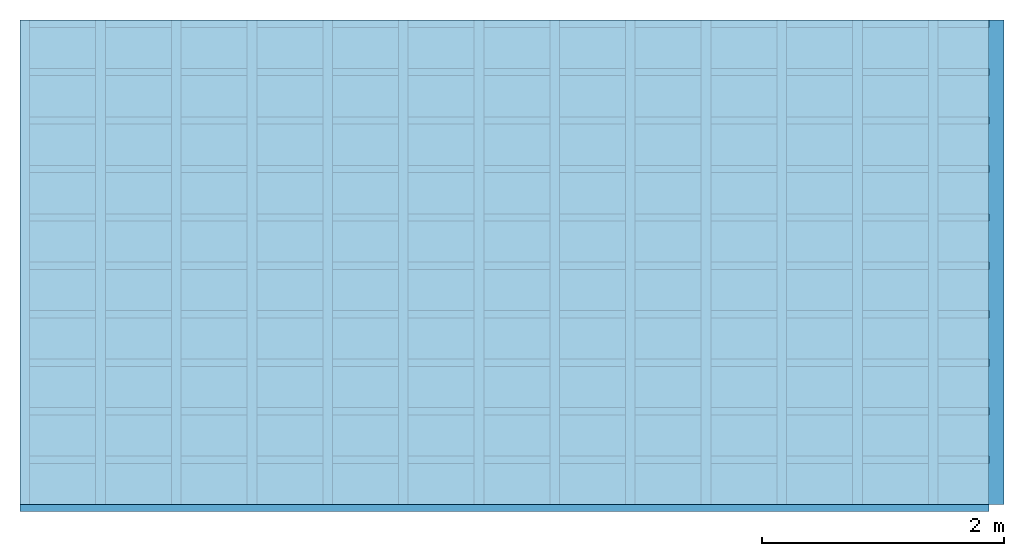
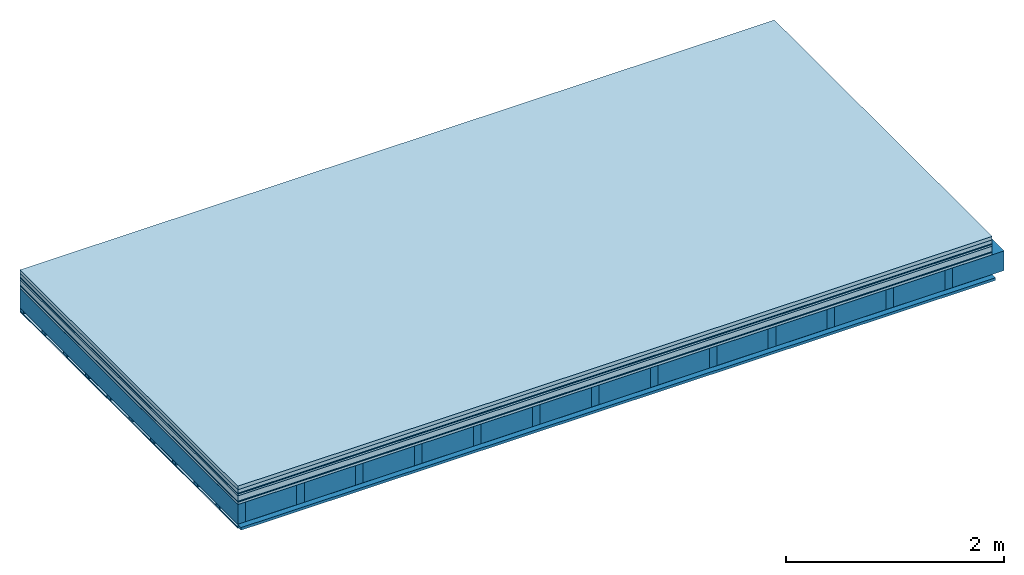
# One storey: 10 plates, 3 members, 1 element without a shape of its own.
"""IFC4 building model written with IfcOpenShell, lengths in metres."""

from ifc_helpers import new_model, si_unit, derived_unit, direction, frame, frame_2d, origin, origin_with_axes, place, context, project, spatial, rectangle, extrude, material, layer, layer_set, type_object, element, aggregate, save


model = new_model("IFC4")

# Units and contexts
plan_context = context("Plan", 3, precision=1e-05, world=origin(), true_north=direction((0.0, 1.0)))
model_context = context("Model", 3, precision=1e-05, world=origin(), true_north=direction((0.0, 1.0)))
ifc_project = project(units=[si_unit("LENGTHUNIT", "METRE"), derived_unit("SOUNDPRESSUREUNIT", [(si_unit("PRESSUREUNIT", "PASCAL", prefix="MICRO"), 0)]), si_unit("ENERGYUNIT", "JOULE", prefix="MEGA"), si_unit("MASSUNIT", "GRAM", prefix="KILO"), derived_unit("THERMALTRANSMITTANCEUNIT", [(si_unit("POWERUNIT", "WATT"), 1), (si_unit("AREAUNIT", "SQUARE_METRE"), -1), (si_unit("THERMODYNAMICTEMPERATUREUNIT", "KELVIN"), -1)]), derived_unit("AREADENSITYUNIT", [(si_unit("MASSUNIT", "GRAM", prefix="KILO"), 1), (si_unit("AREAUNIT", "SQUARE_METRE"), -1)]), derived_unit("USERDEFINED", [(si_unit("ENERGYUNIT", "JOULE", prefix="MEGA"), 1), (si_unit("AREAUNIT", "SQUARE_METRE"), -1)])], contexts=[plan_context, model_context])

# Site, building, storey
site = spatial("IfcSite", under=ifc_project)
building_placement = place(None, origin())
building = spatial("IfcBuilding", under=site, at=building_placement)
storey_placement = place(building_placement, origin())
storey = spatial("IfcBuildingStorey", under=building, at=storey_placement)

# Slab, members, plates
ifc_material_1 = material(Name="Garden plates", Category="02.007")
ifc_layer_1 = layer(ifc_material_1, 0.04, Name="Use and protection layer 3")
ifc_material_2 = material(Name="Gravel 8-16mm", Category="03.011")
ifc_layer_2 = layer(ifc_material_2, 0.04, Name="Use and protection layer 2")
ifc_material_3 = material(Name="Protective layer", Category="09.007")
ifc_layer_3 = layer(ifc_material_3, 0.01, Name="Use and protection layer 1")
ifc_material_4 = material(Name="Bituminous", Category="09.003")
ifc_layer_4 = layer(ifc_material_4, 0.02, Name="Seal")
ifc_material_5 = material(Name="Mineral wool", Category="10.008")
ifc_layer_5 = layer(ifc_material_5, 0.06, Name="Exterior insulation layer 1")
ifc_material_6 = material(Name="Vapor-permeable barrier", Category="09.006")
ifc_layer_6 = layer(ifc_material_6, 0.01, Name="layer / temporary roof")
ifc_material_7 = material(Name="3-layer panels", Category="07.001")
ifc_layer_7 = layer(ifc_material_7, 0.027, Name="above 2nd layer")
ifc_material_8 = material(Name="no composite action")
ifc_layer_8 = layer(ifc_material_8, 0.0, Name="Bond")
ifc_layer_9 = layer(None, 0.22, Name="Support")
ifc_material_9 = material(Name="of the art")
ifc_layer_10 = layer(ifc_material_9, 0.0, Name="Bond")
ifc_material_10 = material(Name="Vapor barrier polyethylene (PE)", Category="09.002")
ifc_layer_11 = layer(ifc_material_10, 0.001, Name="Vapor barrier")
ifc_layer_12 = layer(None, 0.03, Name="Battens / profiles")
ifc_material_11 = material(Name="Plasterboard type A", Category="03.008")
ifc_layer_13 = layer(ifc_material_11, 0.0125, Name="Covering below 1st layer")
ifc_material_12 = material(Category="04.001")
ifc_layer_14 = layer(ifc_material_12, 0.003, Name="Surface below")
ifc_layer_set = layer_set([ifc_layer_1, ifc_layer_2, ifc_layer_3, ifc_layer_4, ifc_layer_5, ifc_layer_6, ifc_layer_7, ifc_layer_8, ifc_layer_9, ifc_layer_10, ifc_layer_11, ifc_layer_12, ifc_layer_13, ifc_layer_14])
slab_type = type_object("IfcSlabType", Name="F0113", PredefinedType="NOTDEFINED", material=ifc_layer_set)
slab_placement = place(None, frame((0.0, 0.0, 0.0), z_axis=(0.0, 0.0, -1.0), x_axis=(1.0, 0.0, 0.0)))
slab = element("IfcSlab", 1, at=slab_placement, inside=storey, type_object=slab_type, material=ifc_layer_set, Name="Slab #1")
ifc_material_13 = material()
member_1_placement = place(slab_placement, origin())
member_1 = element("IfcMember", 2, at=member_1_placement, material=ifc_material_13, Name="Support", context=plan_context, shape_type="SweptSolid", body=[
    extrude(rectangle(XDim=0.08, YDim=0.22, at=frame_2d((0.04, 0.11), x_axis=(1.0, 0.0))), frame((0.0, 4.0, 0.207), z_axis=(0.0, -1.0, 0.0), x_axis=(1.0, 0.0, 0.0)), (0.0, 0.0, 1.0), 4.0),
    extrude(rectangle(XDim=0.08, YDim=0.22, at=frame_2d((0.04, 0.11), x_axis=(1.0, 0.0))), frame((0.625, 4.0, 0.207), z_axis=(0.0, -1.0, 0.0), x_axis=(1.0, 0.0, 0.0)), (0.0, 0.0, 1.0), 4.0),
    extrude(rectangle(XDim=0.08, YDim=0.22, at=frame_2d((0.04, 0.11), x_axis=(1.0, 0.0))), frame((1.25, 4.0, 0.207), z_axis=(0.0, -1.0, 0.0), x_axis=(1.0, 0.0, 0.0)), (0.0, 0.0, 1.0), 4.0),
    extrude(rectangle(XDim=0.08, YDim=0.22, at=frame_2d((0.04, 0.11), x_axis=(1.0, 0.0))), frame((1.875, 4.0, 0.207), z_axis=(0.0, -1.0, 0.0), x_axis=(1.0, 0.0, 0.0)), (0.0, 0.0, 1.0), 4.0),
    extrude(rectangle(XDim=0.08, YDim=0.22, at=frame_2d((0.04, 0.11), x_axis=(1.0, 0.0))), frame((2.5, 4.0, 0.207), z_axis=(0.0, -1.0, 0.0), x_axis=(1.0, 0.0, 0.0)), (0.0, 0.0, 1.0), 4.0),
    extrude(rectangle(XDim=0.08, YDim=0.22, at=frame_2d((0.04, 0.11), x_axis=(1.0, 0.0))), frame((3.125, 4.0, 0.207), z_axis=(0.0, -1.0, 0.0), x_axis=(1.0, 0.0, 0.0)), (0.0, 0.0, 1.0), 4.0),
    extrude(rectangle(XDim=0.08, YDim=0.22, at=frame_2d((0.04, 0.11), x_axis=(1.0, 0.0))), frame((3.75, 4.0, 0.207), z_axis=(0.0, -1.0, 0.0), x_axis=(1.0, 0.0, 0.0)), (0.0, 0.0, 1.0), 4.0),
    extrude(rectangle(XDim=0.08, YDim=0.22, at=frame_2d((0.04, 0.11), x_axis=(1.0, 0.0))), frame((4.375, 4.0, 0.207), z_axis=(0.0, -1.0, 0.0), x_axis=(1.0, 0.0, 0.0)), (0.0, 0.0, 1.0), 4.0),
    extrude(rectangle(XDim=0.08, YDim=0.22, at=frame_2d((0.04, 0.11), x_axis=(1.0, 0.0))), frame((5.0, 4.0, 0.207), z_axis=(0.0, -1.0, 0.0), x_axis=(1.0, 0.0, 0.0)), (0.0, 0.0, 1.0), 4.0),
    extrude(rectangle(XDim=0.08, YDim=0.22, at=frame_2d((0.04, 0.11), x_axis=(1.0, 0.0))), frame((5.625, 4.0, 0.207), z_axis=(0.0, -1.0, 0.0), x_axis=(1.0, 0.0, 0.0)), (0.0, 0.0, 1.0), 4.0),
    extrude(rectangle(XDim=0.08, YDim=0.22, at=frame_2d((0.04, 0.11), x_axis=(1.0, 0.0))), frame((6.25, 4.0, 0.207), z_axis=(0.0, -1.0, 0.0), x_axis=(1.0, 0.0, 0.0)), (0.0, 0.0, 1.0), 4.0),
    extrude(rectangle(XDim=0.08, YDim=0.22, at=frame_2d((0.04, 0.11), x_axis=(1.0, 0.0))), frame((6.875, 4.0, 0.207), z_axis=(0.0, -1.0, 0.0), x_axis=(1.0, 0.0, 0.0)), (0.0, 0.0, 1.0), 4.0),
    extrude(rectangle(XDim=0.08, YDim=0.22, at=frame_2d((0.04, 0.11), x_axis=(1.0, 0.0))), frame((7.5, 4.0, 0.207), z_axis=(0.0, -1.0, 0.0), x_axis=(1.0, 0.0, 0.0)), (0.0, 0.0, 1.0), 4.0),
])
ifc_material_14 = material()
member_2_placement = place(slab_placement, origin())
member_2 = element("IfcMember", 3, at=member_2_placement, material=ifc_material_14, Name="Cavity", context=plan_context, shape_type="SweptSolid", body=[
    extrude(rectangle(XDim=0.545, YDim=0.22, at=frame_2d((0.2725, 0.11), x_axis=(1.0, 0.0))), frame((0.08, 4.0, 0.207), z_axis=(0.0, -1.0, 0.0), x_axis=(1.0, 0.0, 0.0)), (0.0, 0.0, 1.0), 4.0),
    extrude(rectangle(XDim=0.545, YDim=0.22, at=frame_2d((0.2725, 0.11), x_axis=(1.0, 0.0))), frame((0.705, 4.0, 0.207), z_axis=(0.0, -1.0, 0.0), x_axis=(1.0, 0.0, 0.0)), (0.0, 0.0, 1.0), 4.0),
    extrude(rectangle(XDim=0.545, YDim=0.22, at=frame_2d((0.2725, 0.11), x_axis=(1.0, 0.0))), frame((1.33, 4.0, 0.207), z_axis=(0.0, -1.0, 0.0), x_axis=(1.0, 0.0, 0.0)), (0.0, 0.0, 1.0), 4.0),
    extrude(rectangle(XDim=0.545, YDim=0.22, at=frame_2d((0.2725, 0.11), x_axis=(1.0, 0.0))), frame((1.955, 4.0, 0.207), z_axis=(0.0, -1.0, 0.0), x_axis=(1.0, 0.0, 0.0)), (0.0, 0.0, 1.0), 4.0),
    extrude(rectangle(XDim=0.545, YDim=0.22, at=frame_2d((0.2725, 0.11), x_axis=(1.0, 0.0))), frame((2.58, 4.0, 0.207), z_axis=(0.0, -1.0, 0.0), x_axis=(1.0, 0.0, 0.0)), (0.0, 0.0, 1.0), 4.0),
    extrude(rectangle(XDim=0.545, YDim=0.22, at=frame_2d((0.2725, 0.11), x_axis=(1.0, 0.0))), frame((3.205, 4.0, 0.207), z_axis=(0.0, -1.0, 0.0), x_axis=(1.0, 0.0, 0.0)), (0.0, 0.0, 1.0), 4.0),
    extrude(rectangle(XDim=0.545, YDim=0.22, at=frame_2d((0.2725, 0.11), x_axis=(1.0, 0.0))), frame((3.83, 4.0, 0.207), z_axis=(0.0, -1.0, 0.0), x_axis=(1.0, 0.0, 0.0)), (0.0, 0.0, 1.0), 4.0),
    extrude(rectangle(XDim=0.545, YDim=0.22, at=frame_2d((0.2725, 0.11), x_axis=(1.0, 0.0))), frame((4.455, 4.0, 0.207), z_axis=(0.0, -1.0, 0.0), x_axis=(1.0, 0.0, 0.0)), (0.0, 0.0, 1.0), 4.0),
    extrude(rectangle(XDim=0.545, YDim=0.22, at=frame_2d((0.2725, 0.11), x_axis=(1.0, 0.0))), frame((5.08, 4.0, 0.207), z_axis=(0.0, -1.0, 0.0), x_axis=(1.0, 0.0, 0.0)), (0.0, 0.0, 1.0), 4.0),
    extrude(rectangle(XDim=0.545, YDim=0.22, at=frame_2d((0.2725, 0.11), x_axis=(1.0, 0.0))), frame((5.705, 4.0, 0.207), z_axis=(0.0, -1.0, 0.0), x_axis=(1.0, 0.0, 0.0)), (0.0, 0.0, 1.0), 4.0),
    extrude(rectangle(XDim=0.545, YDim=0.22, at=frame_2d((0.2725, 0.11), x_axis=(1.0, 0.0))), frame((6.33, 4.0, 0.207), z_axis=(0.0, -1.0, 0.0), x_axis=(1.0, 0.0, 0.0)), (0.0, 0.0, 1.0), 4.0),
    extrude(rectangle(XDim=0.545, YDim=0.22, at=frame_2d((0.2725, 0.11), x_axis=(1.0, 0.0))), frame((6.955, 4.0, 0.207), z_axis=(0.0, -1.0, 0.0), x_axis=(1.0, 0.0, 0.0)), (0.0, 0.0, 1.0), 4.0),
    extrude(rectangle(XDim=0.545, YDim=0.22, at=frame_2d((0.2725, 0.11), x_axis=(1.0, 0.0))), frame((7.58, 4.0, 0.207), z_axis=(0.0, -1.0, 0.0), x_axis=(1.0, 0.0, 0.0)), (0.0, 0.0, 1.0), 4.0),
])
ifc_material_15 = material()
member_3_placement = place(slab_placement, origin())
member_3 = element("IfcMember", 4, at=member_3_placement, material=ifc_material_15, Name="Battens / profiles", context=plan_context, shape_type="SweptSolid", body=[
    extrude(rectangle(XDim=0.06, YDim=0.03, at=frame_2d((0.03, 0.015), x_axis=(1.0, 0.0))), frame((0.0, 0.0, 0.428), z_axis=(1.0, 0.0, 0.0), x_axis=(0.0, 1.0, 0.0)), (0.0, 0.0, 1.0), 8.0),
    extrude(rectangle(XDim=0.06, YDim=0.03, at=frame_2d((0.03, 0.015), x_axis=(1.0, 0.0))), frame((0.0, 0.4, 0.428), z_axis=(1.0, 0.0, 0.0), x_axis=(0.0, 1.0, 0.0)), (0.0, 0.0, 1.0), 8.0),
    extrude(rectangle(XDim=0.06, YDim=0.03, at=frame_2d((0.03, 0.015), x_axis=(1.0, 0.0))), frame((0.0, 0.8, 0.428), z_axis=(1.0, 0.0, 0.0), x_axis=(0.0, 1.0, 0.0)), (0.0, 0.0, 1.0), 8.0),
    extrude(rectangle(XDim=0.06, YDim=0.03, at=frame_2d((0.03, 0.015), x_axis=(1.0, 0.0))), frame((0.0, 1.2, 0.428), z_axis=(1.0, 0.0, 0.0), x_axis=(0.0, 1.0, 0.0)), (0.0, 0.0, 1.0), 8.0),
    extrude(rectangle(XDim=0.06, YDim=0.03, at=frame_2d((0.03, 0.015), x_axis=(1.0, 0.0))), frame((0.0, 1.6, 0.428), z_axis=(1.0, 0.0, 0.0), x_axis=(0.0, 1.0, 0.0)), (0.0, 0.0, 1.0), 8.0),
    extrude(rectangle(XDim=0.06, YDim=0.03, at=frame_2d((0.03, 0.015), x_axis=(1.0, 0.0))), frame((0.0, 2.0, 0.428), z_axis=(1.0, 0.0, 0.0), x_axis=(0.0, 1.0, 0.0)), (0.0, 0.0, 1.0), 8.0),
    extrude(rectangle(XDim=0.06, YDim=0.03, at=frame_2d((0.03, 0.015), x_axis=(1.0, 0.0))), frame((0.0, 2.4, 0.428), z_axis=(1.0, 0.0, 0.0), x_axis=(0.0, 1.0, 0.0)), (0.0, 0.0, 1.0), 8.0),
    extrude(rectangle(XDim=0.06, YDim=0.03, at=frame_2d((0.03, 0.015), x_axis=(1.0, 0.0))), frame((0.0, 2.8, 0.428), z_axis=(1.0, 0.0, 0.0), x_axis=(0.0, 1.0, 0.0)), (0.0, 0.0, 1.0), 8.0),
    extrude(rectangle(XDim=0.06, YDim=0.03, at=frame_2d((0.03, 0.015), x_axis=(1.0, 0.0))), frame((0.0, 3.2, 0.428), z_axis=(1.0, 0.0, 0.0), x_axis=(0.0, 1.0, 0.0)), (0.0, 0.0, 1.0), 8.0),
    extrude(rectangle(XDim=0.06, YDim=0.03, at=frame_2d((0.03, 0.015), x_axis=(1.0, 0.0))), frame((0.0, 3.6, 0.428), z_axis=(1.0, 0.0, 0.0), x_axis=(0.0, 1.0, 0.0)), (0.0, 0.0, 1.0), 8.0),
    extrude(rectangle(XDim=0.06, YDim=0.03, at=frame_2d((0.03, 0.015), x_axis=(1.0, 0.0))), frame((0.0, 4.0, 0.428), z_axis=(1.0, 0.0, 0.0), x_axis=(0.0, 1.0, 0.0)), (0.0, 0.0, 1.0), 8.0),
])
plate_1_placement = place(slab_placement, origin())
plate_1 = element("IfcPlate", 5, at=plate_1_placement, material=ifc_material_1, Name="Use and protection layer 3", context=plan_context, shape_type="SweptSolid", body=[
    extrude(rectangle(XDim=8.0, YDim=4.0, at=frame_2d((4.0, 2.0), x_axis=(1.0, 0.0))), origin_with_axes(), (0.0, 0.0, 1.0), 0.04),
])
plate_2_placement = place(slab_placement, origin())
plate_2 = element("IfcPlate", 6, at=plate_2_placement, material=ifc_material_2, Name="Use and protection layer 2", context=plan_context, shape_type="SweptSolid", body=[
    extrude(rectangle(XDim=8.0, YDim=4.0, at=frame_2d((4.0, 2.0), x_axis=(1.0, 0.0))), frame((0.0, 0.0, 0.04), z_axis=(0.0, 0.0, 1.0), x_axis=(1.0, 0.0, 0.0)), (0.0, 0.0, 1.0), 0.04),
])
plate_3_placement = place(slab_placement, origin())
plate_3 = element("IfcPlate", 7, at=plate_3_placement, material=ifc_material_3, Name="Use and protection layer 1", context=plan_context, shape_type="SweptSolid", body=[
    extrude(rectangle(XDim=8.0, YDim=4.0, at=frame_2d((4.0, 2.0), x_axis=(1.0, 0.0))), frame((0.0, 0.0, 0.08), z_axis=(0.0, 0.0, 1.0), x_axis=(1.0, 0.0, 0.0)), (0.0, 0.0, 1.0), 0.01),
])
plate_4_placement = place(slab_placement, origin())
plate_4 = element("IfcPlate", 8, at=plate_4_placement, material=ifc_material_4, Name="Seal", context=plan_context, shape_type="SweptSolid", body=[
    extrude(rectangle(XDim=8.0, YDim=4.0, at=frame_2d((4.0, 2.0), x_axis=(1.0, 0.0))), frame((0.0, 0.0, 0.09), z_axis=(0.0, 0.0, 1.0), x_axis=(1.0, 0.0, 0.0)), (0.0, 0.0, 1.0), 0.02),
])
plate_5_placement = place(slab_placement, origin())
plate_5 = element("IfcPlate", 9, at=plate_5_placement, material=ifc_material_5, Name="Exterior insulation layer 1", context=plan_context, shape_type="SweptSolid", body=[
    extrude(rectangle(XDim=8.0, YDim=4.0, at=frame_2d((4.0, 2.0), x_axis=(1.0, 0.0))), frame((0.0, 0.0, 0.11), z_axis=(0.0, 0.0, 1.0), x_axis=(1.0, 0.0, 0.0)), (0.0, 0.0, 1.0), 0.06),
])
plate_6_placement = place(slab_placement, origin())
plate_6 = element("IfcPlate", 10, at=plate_6_placement, material=ifc_material_6, Name="layer / temporary roof", context=plan_context, shape_type="SweptSolid", body=[
    extrude(rectangle(XDim=8.0, YDim=4.0, at=frame_2d((4.0, 2.0), x_axis=(1.0, 0.0))), frame((0.0, 0.0, 0.17), z_axis=(0.0, 0.0, 1.0), x_axis=(1.0, 0.0, 0.0)), (0.0, 0.0, 1.0), 0.01),
])
plate_7_placement = place(slab_placement, origin())
plate_7 = element("IfcPlate", 11, at=plate_7_placement, material=ifc_material_7, Name="above 2nd layer", context=plan_context, shape_type="SweptSolid", body=[
    extrude(rectangle(XDim=8.0, YDim=4.0, at=frame_2d((4.0, 2.0), x_axis=(1.0, 0.0))), frame((0.0, 0.0, 0.18), z_axis=(0.0, 0.0, 1.0), x_axis=(1.0, 0.0, 0.0)), (0.0, 0.0, 1.0), 0.027),
])
plate_8_placement = place(slab_placement, origin())
plate_8 = element("IfcPlate", 12, at=plate_8_placement, material=ifc_material_10, Name="Vapor barrier", context=plan_context, shape_type="SweptSolid", body=[
    extrude(rectangle(XDim=8.0, YDim=4.0, at=frame_2d((4.0, 2.0), x_axis=(1.0, 0.0))), frame((0.0, 0.0, 0.427), z_axis=(0.0, 0.0, 1.0), x_axis=(1.0, 0.0, 0.0)), (0.0, 0.0, 1.0), 0.001),
])
plate_9_placement = place(slab_placement, origin())
plate_9 = element("IfcPlate", 13, at=plate_9_placement, material=ifc_material_11, Name="Covering below 1st layer", context=plan_context, shape_type="SweptSolid", body=[
    extrude(rectangle(XDim=8.0, YDim=4.0, at=frame_2d((4.0, 2.0), x_axis=(1.0, 0.0))), frame((0.0, 0.0, 0.458), z_axis=(0.0, 0.0, 1.0), x_axis=(1.0, 0.0, 0.0)), (0.0, 0.0, 1.0), 0.0125),
])
plate_10_placement = place(slab_placement, origin())
plate_10 = element("IfcPlate", 14, at=plate_10_placement, material=ifc_material_12, Name="Surface below", context=plan_context, shape_type="SweptSolid", body=[
    extrude(rectangle(XDim=8.0, YDim=4.0, at=frame_2d((4.0, 2.0), x_axis=(1.0, 0.0))), frame((0.0, 0.0, 0.4705), z_axis=(0.0, 0.0, 1.0), x_axis=(1.0, 0.0, 0.0)), (0.0, 0.0, 1.0), 0.003),
])
aggregate(slab, [plate_1, plate_2, plate_3, plate_4, plate_5, plate_6, plate_7, member_1, member_2, plate_8, member_3, plate_9, plate_10])

save(model, "model.ifc")
